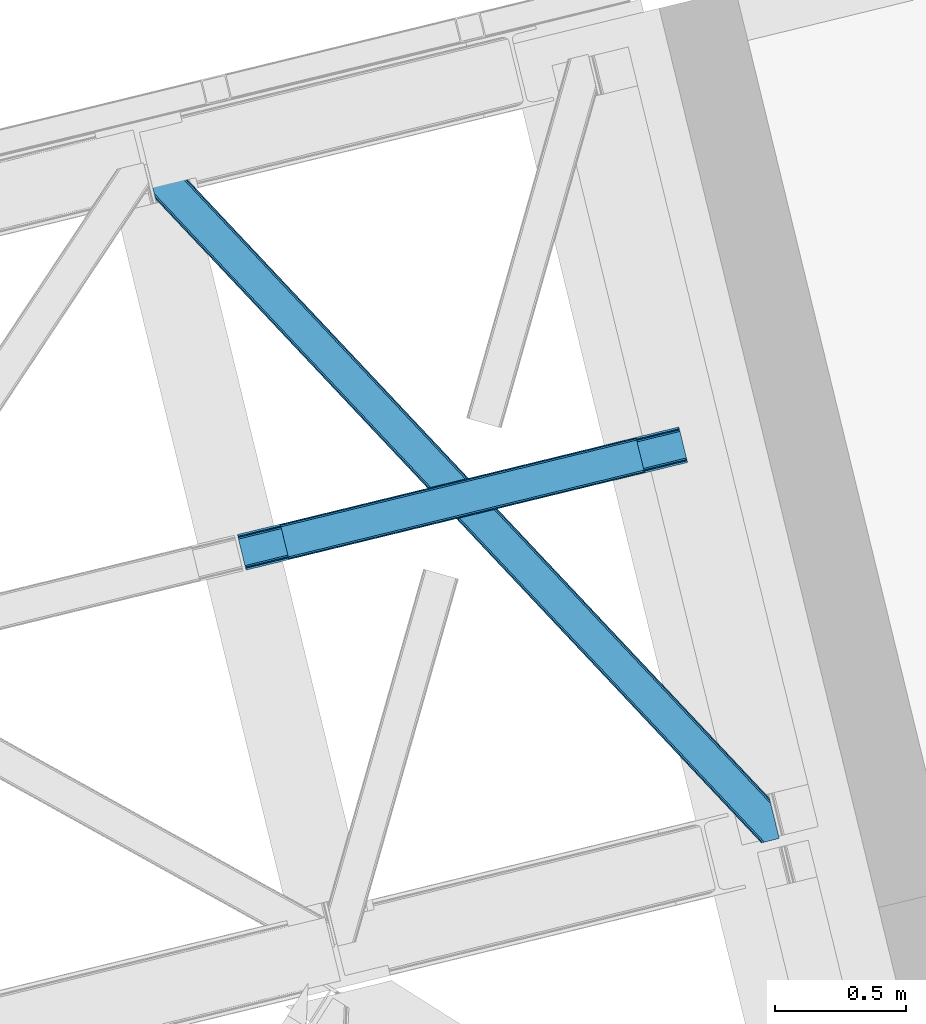
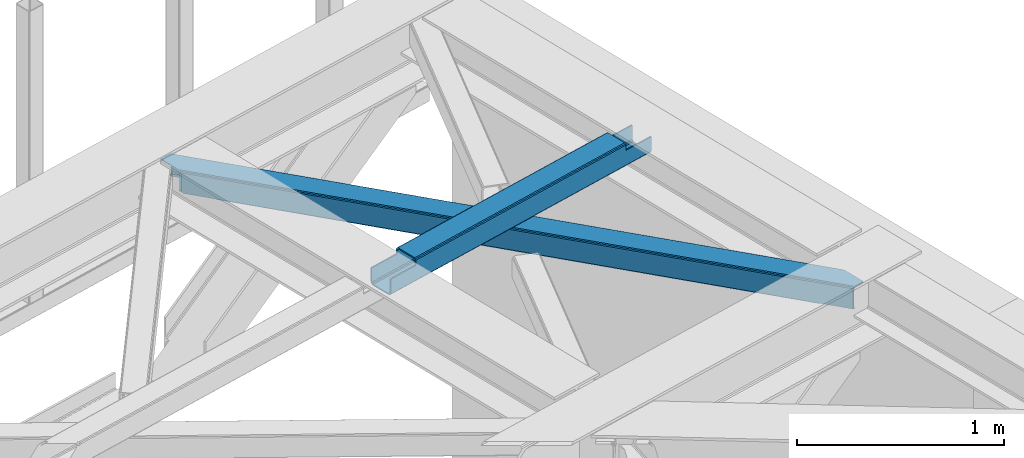
# One storey, part 61 of 67: 1 beam, 1 member.
"""IFC4 building model written with IfcOpenShell, lengths in millimetres."""

from ifc_helpers import new_model, entity, si_unit, converted_unit, derived_unit, direction, frame, origin, place, context, subcontext, project, spatial, triangles, polygons, material, type_object, element, save


model = new_model("IFC4")

# Units and contexts
model_context = context("Model", 3, precision=0.01, world=origin(), true_north=direction((6.12303176911189e-17, 1.0)))
plan_context = context("Plan", 3, precision=0.01, world=origin(), true_north=direction((6.12303176911189e-17, 1.0)))
body_context = subcontext(model_context, "Body", "Model", "MODEL_VIEW")
ifc_project = project(units=[si_unit("LENGTHUNIT", "METRE", prefix="MILLI"), si_unit("AREAUNIT", "SQUARE_METRE"), si_unit("VOLUMEUNIT", "CUBIC_METRE"), converted_unit("PLANEANGLEUNIT", "DEGREE", entity("IfcRatioMeasure", 0.0174532925199433), si_unit("PLANEANGLEUNIT", "RADIAN"), dimensions=[0, 0, 0, 0, 0, 0, 0]), si_unit("MASSUNIT", "GRAM", prefix="KILO"), derived_unit("MASSDENSITYUNIT", [(si_unit("MASSUNIT", "GRAM", prefix="KILO"), 1), (si_unit("LENGTHUNIT", "METRE"), -3)]), derived_unit("MOMENTOFINERTIAUNIT", [(si_unit("LENGTHUNIT", "METRE"), 4)]), si_unit("TIMEUNIT", "SECOND"), si_unit("FREQUENCYUNIT", "HERTZ"), si_unit("THERMODYNAMICTEMPERATUREUNIT", "DEGREE_CELSIUS"), derived_unit("THERMALTRANSMITTANCEUNIT", [(si_unit("MASSUNIT", "GRAM", prefix="KILO"), 1), (si_unit("THERMODYNAMICTEMPERATUREUNIT", "KELVIN"), -1), (si_unit("TIMEUNIT", "SECOND"), -3)]), derived_unit("VOLUMETRICFLOWRATEUNIT", [(si_unit("LENGTHUNIT", "METRE"), 3), (si_unit("TIMEUNIT", "SECOND"), -1)]), derived_unit("MASSFLOWRATEUNIT", [(si_unit("MASSUNIT", "GRAM", prefix="KILO"), 1), (si_unit("TIMEUNIT", "SECOND"), -1)]), derived_unit("ROTATIONALFREQUENCYUNIT", [(si_unit("TIMEUNIT", "SECOND"), -1)]), si_unit("ELECTRICCURRENTUNIT", "AMPERE"), si_unit("ELECTRICVOLTAGEUNIT", "VOLT"), si_unit("POWERUNIT", "WATT"), si_unit("FORCEUNIT", "NEWTON", prefix="KILO"), si_unit("ILLUMINANCEUNIT", "LUX"), si_unit("LUMINOUSFLUXUNIT", "LUMEN"), si_unit("LUMINOUSINTENSITYUNIT", "CANDELA"), derived_unit("USERDEFINED", [(si_unit("MASSUNIT", "GRAM", prefix="KILO"), -1), (si_unit("LENGTHUNIT", "METRE"), -2), (si_unit("TIMEUNIT", "SECOND"), 3), (si_unit("LUMINOUSFLUXUNIT", "LUMEN"), 1)]), derived_unit("LINEARVELOCITYUNIT", [(si_unit("LENGTHUNIT", "METRE"), 1), (si_unit("TIMEUNIT", "SECOND"), -1)]), si_unit("PRESSUREUNIT", "PASCAL"), derived_unit("USERDEFINED", [(si_unit("LENGTHUNIT", "METRE"), -2), (si_unit("MASSUNIT", "GRAM", prefix="KILO"), 1), (si_unit("TIMEUNIT", "SECOND"), -2)]), derived_unit("LINEARFORCEUNIT", [(si_unit("MASSUNIT", "GRAM", prefix="KILO"), 1), (si_unit("LENGTHUNIT", "METRE"), 1), (si_unit("TIMEUNIT", "SECOND"), -2), (si_unit("LENGTHUNIT", "METRE"), -1)]), derived_unit("PLANARFORCEUNIT", [(si_unit("MASSUNIT", "GRAM", prefix="KILO"), 1), (si_unit("LENGTHUNIT", "METRE"), 1), (si_unit("TIMEUNIT", "SECOND"), -2), (si_unit("LENGTHUNIT", "METRE"), -2)])], contexts=[model_context, plan_context])

# Site, building, storey
site_placement = place(None, origin())
site = spatial("IfcSite", under=ifc_project, at=site_placement, CompositionType="ELEMENT")
building_placement = place(site_placement, origin())
building = spatial("IfcBuilding", under=site, at=building_placement, CompositionType="ELEMENT")
storey_placement = place(building_placement, frame((0.0, 0.0, 19800.0)))
storey = spatial("IfcBuildingStorey", under=building, at=storey_placement, CompositionType="ELEMENT", Elevation=19800.0)

# Beam
ifc_material = material(Name="Metal painted (White)")
beam_type = type_object("IfcBeamType", PredefinedType="BEAM")
beam_placement = place(storey_placement, frame((-2546.54274675982, 18519.1957319519, 3967.02022389142)))
element("IfcBeam", 1, at=beam_placement, inside=storey, type_object=beam_type, material=ifc_material, ObjectType="Steel Beam", PredefinedType="BEAM", context=body_context, shape_type="Tessellation", body=[
    polygons([(31.1823923917663, 8.09507685196325, 17.8030399336114), (31.4978703677219, 6.80086440699217, 24.4999999999988), (1720.05534741759, 418.404614024197, 24.4999999999988), (1719.73986944163, 419.698826469164, 17.8030399336114), (30.2839871259127, 11.7806820741907, 12.1256313292298), (1718.84146417578, 423.384431691391, 12.1256313292298), (28.9394286278299, 17.2965800886753, 8.33210818105214), (1717.4969056777, 428.90032970588, 8.33210818105214), (27.3534137403943, 23.8030254244683, 7.00000000000274), (1715.91089079026, 435.406775041673, 7.00000000000274), (4.21622439083855, 118.720708051134, 8.33210818105214), (5.80223927827368, 112.214262715343, 7.00000000000274), (1694.35971632814, 523.818012332546, 7.00000000000274), (1692.77370144071, 530.324457668336, 8.33210818105214), (2.87166589275528, 124.236606065622, 12.1256313292342), (1691.42914294262, 535.840355682825, 12.1256313292342), (1.97326062690218, 127.922211287848, 17.8030399336114), (1690.53073767677, 539.525960905051, 17.8030399336114), (1.65778265093897, 129.216423732819, 24.4999999999988), (1690.2152597008, 540.820173350022, 24.4999999999988), (33.1556530186512, 2.16573425859679e-12, 17.5000000000004), (33.155653018649, 0.0, 99.499999999999), (31.4978703677154, 6.80086440699217, 99.499999999999), (1.65778265093518, 129.216423732817, 99.499999999999), (2.70716782324598e-12, 136.017288139807, 99.499999999999), (3.79003495254437e-12, 136.017288139809, 17.5000000000004), (0.315477975962668, 134.72307569484, 10.803039933613), (1.21388324181576, 131.037470472615, 5.12563132923143), (2.55844173989904, 125.521572458126, 1.33210818105373), (4.14445662733417, 119.015127122333, 0.0), (29.0111963913197, 17.0021610174783, 0.0), (30.5972112787548, 10.4957156816875, 1.33210818105373), (31.9417697768392, 4.97981766719418, 5.12563132923576), (32.8401750426917, 1.29421244497107, 10.803039933613), (1688.55747704987, 547.62103775701, 17.5000000000004), (1688.55747704987, 547.62103775701, 99.499999999999), (1690.2152597008, 540.820173350022, 99.499999999999), (1720.05534741758, 418.404614024193, 99.499999999999), (1721.71313006851, 411.603749617205, 99.499999999999), (1721.71313006851, 411.603749617205, 17.5000000000004), (1721.39765209255, 412.897962062172, 10.803039933613), (1720.4992468267, 416.583567284397, 5.12563132923576), (1719.15468832862, 422.099465298888, 1.33210818105373), (1717.56867344118, 428.605910634677, 0.0), (1692.7019336772, 530.618876739533, 0.0), (1691.11591878976, 537.125322075326, 1.33210818105373), (1689.77136029168, 542.641220089815, 5.12563132923143), (1688.87295502583, 546.326825312043, 10.803039933613), (1555.87153982994, 378.383074424505, 115.5000123926), (1555.92790791481, 378.396813643123, 100.117303289864), (1556.83460164982, 378.617830401818, 99.499999999999), (194.718606580802, 46.5876811586757, 99.5063429816656), (195.631369831917, 46.8101414945073, 100.117301735448), (195.69016819363, 46.824474122359, 115.5), (1558.49238430075, 371.81696599483, 99.499999999999), (1557.58582420851, 371.595981821318, 100.117303484932), (1557.52624144083, 371.581458788976, 122.500007895425), (197.345360928056, 40.0229783796067, 122.500002534479), (197.338587096744, 40.0213271441522, 100.500009163303), (196.748205195733, 39.8773799905108, 99.5697919021647), (1526.99452348773, 501.033356598336, 99.5063429816656), (1526.08541462826, 500.811786435622, 100.117299778624), (1526.02904654339, 500.798047217008, 115.50000888136), (165.85008047685, 169.240033448186, 115.5), (165.840462203346, 169.237688832046, 100.50000941238), (165.250325295043, 169.093836777335, 99.5761204674868), (1524.96492487281, 507.743657766505, 99.5697919021647), (163.22074576778, 175.804071762184, 99.499999999999), (164.133244938524, 176.026503182401, 100.117301984524), (164.18943998764, 176.04020120897, 122.500002796667), (1524.36791556689, 507.598095225085, 122.500003994045), (1524.37801885572, 507.600558639654, 100.500018741102), (1524.68002972126, 506.303062602923, 129.196959150505), (1525.57336524685, 502.616221261231, 134.874360354937), (1526.91465625092, 497.099526556424, 138.667878733795), (1528.49970333692, 490.592845248349, 139.999985502214), (1553.37045238386, 388.580856699036, 139.999991354279), (1554.95794650144, 382.074772033634, 138.667885332354), (1556.30620606188, 376.559776423407, 134.874367586349), (1557.20997076909, 372.875477956454, 129.196966804773), (1555.55835019824, 379.677844820524, 122.196975799125), (1554.65458549103, 383.362143287481, 127.874376580702), (1553.3063259306, 388.877138897706, 131.667894326702), (1551.71883181301, 395.383223563109, 133.000000348631), (1530.164182639, 483.793613639179, 132.999995276841), (1528.579135553, 490.300294947254, 131.667888508414), (1527.23784454893, 495.816989652061, 127.874370129564), (1526.34450902334, 499.503830993753, 122.196968925133), (164.878528418712, 169.003207355194, 99.499999999999), (193.131726453735, 57.3201898040421, 131.667891818946), (191.5457115663, 63.826635139835, 133.0), (194.476284951818, 51.8042917895531, 127.874368670764), (195.374690217671, 48.1186865673279, 122.196960066391), (169.994537104178, 152.237872430709, 133.0), (166.165558452807, 167.945821003219, 122.196960066391), (167.06396371866, 164.260215780991, 127.874368670764), (168.408522216743, 158.744317766505, 131.667891818946), (197.031411944076, 41.3175635421181, 129.196961104604), (196.136488323068, 45.0040174739068, 134.874366301861), (194.794244157318, 50.5204796458773, 138.667887185257), (193.209023953587, 57.0271186992037, 139.999994588639), (168.341882306944, 159.039986838394, 139.999994981919), (166.755021471193, 165.546225960036, 138.667887628704), (165.408105180737, 171.061549222932, 134.874366787843), (164.50618923097, 174.746298656831, 129.196961619)], [[[1, 2, 3, 4]], [[5, 1, 4, 6]], [[7, 5, 6, 8]], [[9, 7, 8, 10]], [[11, 12, 13, 14]], [[15, 11, 14, 16]], [[17, 15, 16, 18]], [[19, 17, 18, 20]], [[12, 9, 10, 13]], [[21, 22, 23, 2, 1, 5, 7, 9, 12, 11, 15, 17, 19, 24, 25, 26, 27, 28, 29, 30, 31, 32, 33, 34]], [[35, 36, 37, 20, 18, 16, 14, 13, 10, 8, 6, 4, 3, 38, 39, 40, 41, 42, 43, 44, 45, 46, 47, 48]], [[49, 50, 51, 38, 3, 2, 23, 52, 53, 54]], [[55, 39, 38, 51]], [[39, 55, 56, 57, 58, 59, 60, 22, 21, 40]], [[32, 31, 44, 43]], [[33, 32, 43, 42]], [[34, 33, 42, 41]], [[21, 34, 41, 40]], [[31, 30, 45, 44]], [[27, 26, 35, 48]], [[28, 27, 48, 47]], [[29, 28, 47, 46]], [[30, 29, 46, 45]], [[20, 37, 61, 62, 63, 64, 65, 66, 24, 19]], [[67, 36, 35, 26, 25, 68, 69, 70, 71, 72]], [[36, 67, 61, 37]], [[72, 71, 73, 74, 75, 76, 77, 78, 79, 80, 57, 56, 50, 49, 81, 82, 83, 84, 85, 86, 87, 88, 63, 62]], [[60, 52, 23, 22]], [[25, 24, 89, 68]], [[90, 91, 84, 83]], [[92, 90, 83, 82]], [[93, 92, 82, 81]], [[54, 93, 81, 49]], [[94, 85, 84, 91]], [[95, 64, 63, 88]], [[96, 95, 88, 87]], [[97, 96, 87, 86]], [[94, 97, 86, 85]], [[65, 64, 95, 96, 97, 94, 91, 90, 92, 93, 54, 53, 59, 58, 98, 99, 100, 101, 102, 103, 104, 105, 70, 69]], [[98, 58, 57, 80]], [[99, 98, 80, 79]], [[100, 99, 79, 78]], [[101, 100, 78, 77]], [[77, 76, 102, 101]], [[103, 102, 76, 75]], [[104, 103, 75, 74]], [[105, 104, 74, 73]], [[70, 105, 73, 71]]], closed=False),
])

# Member
member_type = type_object("IfcMemberType", PredefinedType="BRACE")
member_placement = place(storey_placement, frame((-2893.848072052, 17476.1728088379, 3823.02086791992)))
element("IfcMember", 2, at=member_placement, inside=storey, type_object=member_type, ObjectType="Steel Horizontal Brace", PredefinedType="BRACE", context=body_context, shape_type="Tessellation", body=[
    triangles([(2390.20879182816, 136.983499145506, 139.998431396481), (2386.99318141937, 150.175717163085, 138.668280029295), (56.5227127075195, 2617.59836425781, 139.998431396481), (64.0010353088378, 2619.42150878906, 138.668280029295), (2384.26711235046, 161.358755493166, 134.873162841795), (70.3451248168944, 2620.96792602539, 134.873162841795), (2382.44560289383, 168.831555175781, 129.196765136716), (74.5788780212401, 2622.00042114258, 129.196765136716), (2381.80599803925, 171.455813598634, 122.499499511716), (76.0700660705566, 2622.36318969727, 122.499499511716), (2006.64328708649, 570.234960937501, 17.4989318847656), (2381.80599803925, 171.455813598634, 17.4989318847656), (1617.6124546051, 983.763208007811, 17.4989318847656), (1228.57718925476, 1397.2902923584, 17.4989318847656), (450.510873413086, 2224.3456237793, 17.4989318847656), (76.0700660705566, 2622.36318969727, 17.4989318847656), (839.546284103394, 1810.81853942871, 17.4989318847656), (26.1158477783201, 2496.68248901367, 139.998431396481), (0.0, 2603.82013549805, 139.998431396481), (2370.43223733902, 4.76366271972802, 139.998431396481), (2419.52200984955, 16.7303741455071, 139.998431396481), (2350.88942584991, 0.0, 122.499499511716), (2352.37603569031, 0.362768554688955, 129.196765136716), (34.5188232421874, 2462.2125, 122.499499511716), (33.8790367126462, 2464.83559570312, 129.196765136716), (2356.61443977356, 1.395263671875, 134.873162841795), (32.0576362609863, 2472.30723266601, 134.873162841795), (2362.95402374268, 2.94051818847583, 138.668280029295), (29.3316398620605, 2483.49259643555, 138.668280029295), (1193.06046180725, 1230.72371520996, 17.4989318847656), (1583.89125709534, 815.290933227538, 17.4989318847656), (1974.7174741745, 399.856988525389, 17.4989318847656), (2350.88942584991, 0.0, 17.4989318847656), (802.234317398071, 1646.15765991211, 17.4989318847656), (411.408027648926, 2061.59276733398, 17.4989318847656), (34.5188232421874, 2462.2125, 17.4989318847656), (2364.4315861702, 3.30096130371021, 127.873590087889), (2370.77113380432, 4.84621582031104, 131.666381835938), (2360.19314575195, 2.26730346679688, 122.19719238281), (2378.2538892746, 6.67052307129052, 132.998858642575), (2419.52200984955, 16.7303741455071, 132.998858642575), (2358.70653591156, 1.90569763183521, 115.49992675781), (2358.70653591156, 1.90569763183521, 24.4985046386719), (2360.19314575195, 2.26730346679688, 17.8035644531228), (2352.67877883911, 0.436019897460938, 10.8691040039048), (2353.04928674698, 0.526712036131357, 9.49942016601563), (2364.4315861702, 3.30096130371021, 12.1248413085923), (2368.18651685715, 4.21602172851635, 9.49942016601563), (1982.47063465118, 401.827798461913, 24.4985046386719), (1588.94283828735, 820.135986328125, 24.4985046386719), (1195.4104637146, 1238.44417419434, 24.4985046386719), (31.1576911926268, 2476.00003051758, 115.49992675781), (408.350074768066, 2075.05938720703, 24.4985046386719), (31.1576911926268, 2476.00003051758, 24.4985046386719), (801.882594680786, 1656.75236206055, 24.4985046386719), (25.9705078124998, 2497.28012695313, 131.666381835938), (22.7547157287595, 2510.4723449707, 132.998858642575), (28.6965042114257, 2486.09708862305, 127.873590087889), (30.517904663086, 2478.6231262207, 122.19719238281), (30.3873893737791, 2479.16030273437, 17.8710021972656), (34.5051612854004, 2462.26831054688, 16.4989929199219), (30.22809677124, 2479.8137512207, 16.4989929199219), (0.0, 2603.82013549805, 132.998858642575), (48.7057479858399, 2615.6938293457, 132.998858642575), (2393.56992387772, 123.194805908202, 132.998858642575), (2385.16713008881, 157.66712036133, 115.49992675781), (2385.80673494339, 155.042861938477, 122.19719238281), (66.7619132995605, 2620.09588623047, 122.19719238281), (68.2484504699705, 2620.4563293457, 115.49992675781), (2387.62824440002, 147.570062255858, 127.873590087889), (62.527869415283, 2619.06339111328, 127.873590087889), (2390.35431346893, 136.387023925781, 131.666381835938), (56.1837799072264, 2617.51697387695, 131.666381835938), (1226.23169288635, 1389.57215881348, 24.4985046386719), (1617.96868286133, 973.170831298827, 24.4985046386719), (2009.70560016632, 556.76950378418, 24.4985046386719), (2385.16713008881, 157.66712036133, 24.4985046386719), (834.490197372436, 1805.9723236084, 24.4985046386719), (442.753207397461, 2222.37365112305, 24.4985046386719), (68.2484504699705, 2620.4563293457, 24.4985046386719), (66.7619132995605, 2620.09588623047, 17.8035644531228), (74.2762802124021, 2621.92600708008, 10.8691040039048), (73.9056632995603, 2621.83764038086, 9.49942016601563), (62.527869415283, 2619.06339111328, 12.1248413085923), (58.7728660583493, 2618.14716796875, 9.49942016601563), (2385.9372502327, 154.508010864258, 17.8710021972656), (2386.09654283524, 153.854562377928, 16.4989929199219), (2381.81973266602, 171.398840332033, 16.4989929199219), (41.7939605712891, 2456.42215576172, 10.8016662597656), (36.8073463439941, 2482.3787109375, 9.49942016601563), (34.7757843017575, 2479.63701782226, 12.1248413085923), (43.3136352539063, 2455.68731689453, 9.49942016601563), (170.418958282471, 2340.35482177734, 9.49942016601563), (155.286451721192, 2336.66434936523, 9.49942016601563), (180.780244445801, 2508.2352722168, 9.49942016601563), (187.286533355713, 2481.54155273438, 9.49942016601563), (181.188068389893, 2507.60275268555, 9.25292358398292), (187.878357696533, 2480.72532348633, 9.42268066406177), (181.610426330567, 2506.94930419922, 8.99945068359375), (188.450415802002, 2479.24401855469, 9.11572265625), (182.028424072265, 2506.29585571289, 8.74597778320094), (189.028287506103, 2477.75573730469, 8.80643920898365), (182.436248016357, 2505.66333618164, 8.49948120117188), (189.60005493164, 2476.27443237305, 8.49948120117188), (2381.54910964966, 154.028970336913, 12.1248413085923), (2374.53078804016, 177.24383239746, 10.8016662597656), (2379.51751127243, 151.288439941407, 9.49942016601563), (2373.01111335754, 177.979833984376, 9.49942016601563), (2233.21012630463, 306.80569152832, 9.49942016601563), (2248.34285087585, 310.495001220705, 9.49942016601563), (2005.67379684448, 569.32222595215, 10.8016662597656), (2002.91328220367, 566.723547363283, 5.12526855468604), (2244.78223972321, 309.626449584961, 5.12526855468604), (449.541455841064, 2223.43405151367, 10.8016662597656), (446.776508331299, 2220.83421020508, 5.12526855468604), (183.700996398926, 2500.47295532226, 5.12526855468604), (442.640714263916, 2216.94375, 1.33247680663771), (186.427283477783, 2489.28991699219, 1.33247680663771), (437.765721130371, 2212.35565795899, 0.0), (189.642784881592, 2476.09769897461, 0.0), (2238.43815021515, 308.080032348633, 1.33247680663771), (2230.95990028381, 306.256887817384, 0.0), (1998.77770614624, 562.833087158204, 1.33247680663771), (1993.89820747375, 558.24383239746, 0.0), (1616.64303703308, 982.850473022459, 10.8016662597656), (1227.60762634277, 1396.37755737305, 10.8016662597656), (838.572215652466, 1809.90464172363, 10.8016662597656), (1613.87794418335, 980.250631713869, 5.12526855468604), (1224.84253349304, 1393.77771606445, 5.12526855468604), (835.811773681641, 1807.30596313476, 5.12526855468604), (1609.74229545593, 976.36017150879, 1.33247680663771), (1220.71153564453, 1389.8884185791, 1.33247680663771), (831.676124954224, 1803.41666564941, 1.33247680663771), (1604.86730232239, 971.772079467773, 0.0), (1215.83203697205, 1385.29916381836, 0.0), (826.796626281738, 1798.82741088867, 0.0), (2008.73153171539, 555.855606079102, 17.8035644531228), (2005.9709444046, 553.256927490234, 12.1248413085923), (439.023202514648, 2218.86223754883, 12.1248413085923), (189.798298645019, 2475.46052856445, 8.4111145019524), (434.887699127197, 2214.97177734375, 8.33204956054396), (193.003916931152, 2462.31016845703, 6.99957275390625), (2001.83544101715, 549.366467285156, 8.33204956054396), (1996.95594234467, 544.777212524416, 6.99957275390625), (2223.14279022217, 304.352352905273, 6.99957275390625), (2230.46741580963, 306.137127685546, 8.81806640624927), (430.008055114746, 2210.38368530274, 6.99957275390625), (441.783789825439, 2221.45975341797, 17.8035644531228), (1610.09852371216, 965.767794799805, 8.33204956054396), (1605.21902503967, 961.178540039062, 6.99957275390625), (1213.4820350647, 1377.57986755371, 6.99957275390625), (1218.36153373718, 1382.16912231445, 8.33204956054396), (821.745045089722, 1793.98119506836, 6.99957275390625), (826.624543762207, 1798.5704498291, 8.33204956054396), (1614.23402709961, 969.658255004884, 12.1248413085923), (1222.49703712463, 1386.05958251953, 12.1248413085923), (830.760192489624, 1802.46091003418, 12.1248413085923), (1616.9946144104, 972.256933593751, 17.8035644531228), (1225.25762443542, 1388.6582611084, 17.8035644531228), (833.520634460449, 1805.05958862305, 17.8035644531228), (219.79792098999, 2352.39129638672, 0.0), (219.79792098999, 2352.39129638672, 6.99957275390625), (173.166464996338, 2341.02454833984, 8.81806640624927), (180.486367034912, 2342.80816040039, 6.99957275390625), (172.669402313232, 2340.90130004883, 0.0), (165.191079711914, 2339.08048095703, 1.33247680663771), (158.846990203857, 2337.5340637207, 5.12526855468604), (424.15317993164, 2073.5827331543, 0.0), (814.97932434082, 1658.14878845215, 0.0), (1205.81011962891, 1242.71600646973, 0.0), (1987.46262645721, 411.846954345703, 0.0), (1596.63640937805, 827.282061767579, 0.0), (2192.71020011902, 296.934201049804, 0.0), (2226.68196372986, 157.568289184572, 0.0), (421.095517730713, 2087.04935302735, 6.99957275390625), (814.627746963501, 1668.74349060059, 6.99957275390625), (1208.15561599731, 1250.43414001465, 6.99957275390625), (1995.22029247284, 413.820089721681, 6.99957275390625), (2192.71020011902, 296.934201049804, 6.99957275390625), (2223.3208316803, 171.356982421876, 6.99957275390625), (1601.68799057007, 832.127114868163, 6.99957275390625), (1975.68703708649, 400.768560791017, 10.8016662597656), (412.377445220947, 2062.50433959961, 10.8016662597656), (415.142683410645, 2065.1041809082, 5.12526855468604), (2235.13660755157, 126.065560913084, 9.25292358398292), (2234.7142496109, 126.717846679687, 8.99945068359375), (2235.54457683563, 125.433041381835, 9.49942016601563), (2234.29632453918, 127.372457885744, 8.74597778320094), (2233.88835525513, 128.004977416993, 8.49948120117188), (1978.45205726624, 403.368402099608, 5.12526855468604), (2232.62367954254, 133.193032836913, 5.12526855468604), (2229.89761047363, 144.376071166993, 1.33247680663771), (1982.58312778473, 407.257699584959, 1.33247680663771), (419.278186798096, 2068.99464111328, 1.33247680663771), (1591.75691070557, 822.692807006835, 1.33247680663771), (1200.93062095642, 1238.12675170898, 1.33247680663771), (810.104331207275, 1653.56069641113, 1.33247680663771), (1587.62126197815, 818.802346801756, 5.12526855468604), (1196.79511756897, 1234.2362915039, 5.12526855468604), (805.968827819824, 1649.67023620605, 5.12526855468604), (1584.86082000732, 816.203668212889, 10.8016662597656), (1194.03453025818, 1231.63761291504, 10.8016662597656), (803.203734970093, 1647.07039489746, 10.8016662597656), (1990.34079380035, 409.230834960938, 8.33204956054396), (2227.21637878418, 155.690496826173, 8.8831787109375), (2226.72454833984, 157.393881225587, 8.49948120117188), (1986.20521774292, 405.340374755859, 12.1248413085923), (2229.03814258575, 152.124435424805, 9.49942016601563), (2228.43301963806, 153.310409545898, 9.2947814941399), (2227.82150173187, 154.503359985352, 9.08781738280959), (2226.52637729645, 158.206622314454, 8.4111145019524), (416.220524597168, 2082.46126098633, 8.33204956054396), (412.084730529785, 2078.5731262207, 12.1248413085923), (409.319783020019, 2075.97328491211, 17.8035644531228), (1983.44470310211, 402.741696166991, 17.8035644531228), (1589.91240119934, 821.048721313477, 17.8035644531228), (1196.38002662659, 1239.35690917969, 17.8035644531228), (802.852157592773, 1657.6650970459, 17.8035644531228), (1592.67284317017, 823.647399902344, 12.1248413085923), (1199.14497413635, 1241.95675048828, 12.1248413085923), (805.612599563598, 1660.26377563476, 12.1248413085923), (1596.80849189758, 827.537860107423, 8.33204956054396), (1203.28062286377, 1245.84604797363, 8.33204956054396), (809.748248291015, 1664.15423583984, 8.33204956054396)], [[1, 2, 3], [4, 3, 2], [2, 5, 4], [6, 4, 5], [5, 7, 6], [8, 6, 7], [7, 9, 8], [10, 8, 9], [11, 9, 12], [9, 11, 13], [9, 14, 10], [14, 9, 13], [15, 16, 10], [17, 10, 14], [10, 17, 15], [3, 18, 1], [3, 19, 18], [20, 1, 18], [21, 1, 20], [22, 23, 24], [25, 24, 23], [23, 26, 25], [27, 25, 26], [26, 28, 27], [29, 27, 28], [28, 20, 29], [18, 29, 20], [30, 22, 24], [22, 31, 32], [30, 31, 22], [32, 33, 22], [34, 24, 35], [24, 34, 30], [36, 35, 24], [37, 38, 28], [26, 37, 28], [37, 26, 23], [39, 37, 23], [39, 23, 22], [38, 20, 28], [21, 40, 41], [21, 20, 40], [38, 40, 20], [39, 22, 42], [43, 33, 44], [22, 43, 42], [33, 45, 44], [22, 33, 43], [46, 47, 45], [47, 44, 45], [48, 47, 46], [49, 42, 43], [42, 49, 50], [42, 51, 52], [51, 42, 50], [53, 54, 52], [55, 52, 51], [52, 55, 53], [40, 38, 56], [56, 57, 40], [38, 37, 58], [58, 56, 38], [37, 39, 59], [59, 58, 37], [39, 42, 52], [52, 59, 39], [60, 61, 62], [24, 36, 54], [36, 60, 54], [54, 52, 24], [36, 61, 60], [59, 24, 52], [25, 24, 59], [27, 59, 58], [59, 27, 25], [58, 29, 27], [56, 29, 58], [56, 57, 18], [56, 18, 29], [57, 19, 18], [57, 63, 19], [57, 64, 65], [64, 57, 63], [65, 40, 57], [41, 40, 65], [66, 67, 68], [68, 69, 66], [67, 70, 71], [71, 68, 67], [70, 72, 73], [73, 71, 70], [72, 65, 64], [64, 73, 72], [74, 66, 69], [66, 75, 76], [74, 75, 66], [76, 77, 66], [78, 69, 79], [69, 78, 74], [80, 79, 69], [71, 73, 4], [6, 71, 4], [71, 6, 8], [68, 71, 8], [68, 8, 10], [73, 3, 4], [19, 64, 63], [19, 3, 64], [73, 64, 3], [68, 10, 69], [80, 16, 81], [10, 80, 69], [16, 82, 81], [10, 16, 80], [83, 84, 82], [84, 81, 82], [85, 84, 83], [70, 5, 2], [65, 72, 1], [72, 70, 2], [86, 87, 88], [41, 65, 21], [1, 21, 65], [72, 2, 1], [86, 12, 77], [9, 66, 77], [77, 12, 9], [86, 88, 12], [9, 67, 66], [67, 5, 70], [5, 67, 7], [9, 7, 67], [89, 90, 91], [89, 92, 90], [91, 61, 89], [62, 61, 91], [92, 90, 93], [93, 94, 92], [85, 83, 95], [95, 96, 85], [97, 98, 96], [99, 100, 98], [101, 102, 100], [103, 104, 102], [102, 101, 103], [100, 99, 101], [98, 97, 99], [96, 95, 97], [88, 105, 106], [105, 88, 87], [107, 106, 105], [107, 108, 106], [109, 110, 108], [108, 107, 109], [12, 88, 106], [111, 106, 110], [110, 112, 111], [110, 113, 112], [106, 108, 110], [114, 101, 99], [101, 114, 103], [114, 97, 95], [97, 114, 99], [95, 82, 114], [95, 83, 82], [114, 115, 116], [116, 103, 114], [114, 82, 16], [16, 15, 114], [115, 117, 118], [118, 116, 115], [117, 119, 120], [120, 118, 117], [121, 122, 123], [124, 123, 122], [113, 121, 112], [123, 112, 121], [12, 106, 11], [111, 11, 106], [11, 111, 125], [125, 13, 11], [13, 125, 14], [126, 14, 125], [14, 126, 17], [127, 17, 126], [17, 127, 15], [114, 15, 127], [111, 112, 125], [128, 125, 112], [125, 128, 126], [129, 126, 128], [126, 129, 130], [130, 127, 126], [127, 130, 115], [115, 114, 127], [112, 123, 131], [131, 128, 112], [128, 131, 132], [132, 129, 128], [129, 132, 133], [133, 130, 129], [130, 133, 117], [117, 115, 130], [123, 124, 131], [134, 131, 124], [131, 134, 132], [135, 132, 134], [132, 135, 133], [136, 133, 135], [133, 136, 119], [119, 117, 133], [137, 138, 105], [105, 87, 137], [137, 86, 77], [139, 104, 140], [102, 139, 100], [102, 104, 139], [98, 100, 139], [96, 139, 84], [84, 85, 96], [96, 98, 139], [141, 140, 142], [143, 144, 145], [138, 143, 146], [146, 109, 138], [107, 105, 109], [138, 109, 105], [145, 146, 143], [142, 147, 141], [140, 141, 139], [139, 148, 81], [81, 84, 139], [148, 79, 80], [80, 81, 148], [77, 76, 137], [87, 86, 137], [144, 143, 149], [149, 150, 144], [150, 149, 151], [152, 151, 149], [151, 152, 153], [154, 153, 152], [153, 154, 147], [141, 147, 154], [143, 138, 149], [155, 149, 138], [149, 155, 152], [156, 152, 155], [152, 156, 157], [157, 154, 152], [154, 157, 141], [139, 141, 157], [138, 137, 158], [158, 155, 138], [155, 158, 159], [159, 156, 155], [156, 159, 157], [160, 157, 159], [157, 160, 148], [148, 139, 157], [137, 76, 75], [75, 158, 137], [158, 75, 74], [74, 159, 158], [159, 74, 78], [78, 160, 159], [160, 78, 79], [79, 148, 160], [104, 120, 140], [118, 104, 116], [104, 118, 120], [104, 103, 116], [140, 120, 142], [142, 161, 162], [161, 142, 120], [163, 164, 165], [93, 165, 166], [166, 167, 93], [161, 164, 162], [164, 161, 165], [167, 94, 93], [165, 93, 163], [168, 165, 161], [119, 168, 161], [119, 161, 120], [136, 168, 119], [169, 168, 136], [135, 169, 136], [169, 135, 170], [124, 171, 172], [170, 134, 172], [134, 170, 135], [134, 124, 172], [124, 173, 171], [171, 173, 174], [122, 173, 124], [153, 147, 175], [175, 176, 153], [176, 151, 153], [151, 176, 177], [147, 164, 175], [162, 147, 142], [147, 162, 164], [145, 144, 178], [178, 179, 145], [179, 178, 180], [144, 181, 178], [150, 177, 181], [177, 150, 151], [144, 150, 181], [146, 145, 122], [109, 122, 121], [121, 113, 109], [173, 145, 179], [145, 173, 122], [113, 110, 109], [122, 109, 146], [182, 45, 33], [36, 61, 89], [183, 89, 94], [94, 184, 183], [94, 167, 184], [89, 92, 94], [185, 182, 186], [185, 187, 182], [182, 188, 186], [182, 189, 188], [187, 45, 182], [187, 46, 45], [182, 190, 191], [191, 189, 182], [192, 191, 190], [190, 193, 192], [174, 192, 193], [193, 171, 174], [168, 194, 165], [166, 165, 194], [194, 184, 166], [167, 166, 184], [183, 35, 89], [36, 89, 35], [33, 32, 182], [171, 193, 195], [195, 172, 171], [172, 195, 196], [196, 170, 172], [170, 196, 197], [197, 169, 170], [169, 197, 194], [194, 168, 169], [193, 190, 195], [198, 195, 190], [195, 198, 196], [199, 196, 198], [196, 199, 200], [200, 197, 196], [197, 200, 184], [184, 194, 197], [190, 182, 201], [201, 198, 190], [198, 201, 202], [202, 199, 198], [199, 202, 200], [203, 200, 202], [200, 203, 184], [183, 184, 203], [182, 32, 201], [31, 201, 32], [201, 31, 202], [30, 202, 31], [202, 30, 34], [34, 203, 202], [203, 34, 35], [35, 183, 203], [204, 205, 206], [207, 208, 209], [209, 204, 207], [209, 210, 204], [205, 204, 210], [206, 211, 204], [47, 48, 208], [208, 207, 47], [204, 211, 180], [212, 175, 164], [213, 212, 163], [163, 93, 213], [214, 213, 91], [91, 62, 214], [214, 60, 54], [54, 53, 214], [62, 60, 214], [213, 93, 91], [90, 91, 93], [164, 163, 212], [180, 178, 204], [44, 47, 207], [207, 215, 44], [43, 44, 215], [215, 49, 43], [49, 215, 216], [216, 50, 49], [50, 216, 51], [217, 51, 216], [51, 217, 55], [218, 55, 217], [55, 218, 53], [214, 53, 218], [215, 207, 216], [219, 216, 207], [216, 219, 220], [220, 217, 216], [217, 220, 221], [221, 218, 217], [218, 221, 213], [213, 214, 218], [207, 204, 219], [222, 219, 204], [219, 222, 220], [223, 220, 222], [220, 223, 221], [224, 221, 223], [221, 224, 213], [212, 213, 224], [204, 178, 222], [181, 222, 178], [222, 181, 223], [177, 223, 181], [223, 177, 224], [176, 224, 177], [224, 176, 212], [175, 212, 176], [174, 211, 206], [179, 180, 173], [180, 211, 174], [174, 173, 180], [192, 174, 206], [206, 189, 191], [191, 192, 206], [189, 206, 205], [188, 205, 210], [186, 210, 209], [185, 209, 208], [208, 187, 185], [209, 185, 186], [210, 186, 188], [205, 188, 189], [187, 208, 48], [48, 46, 187]]),
])

save(model, "model.ifc")
